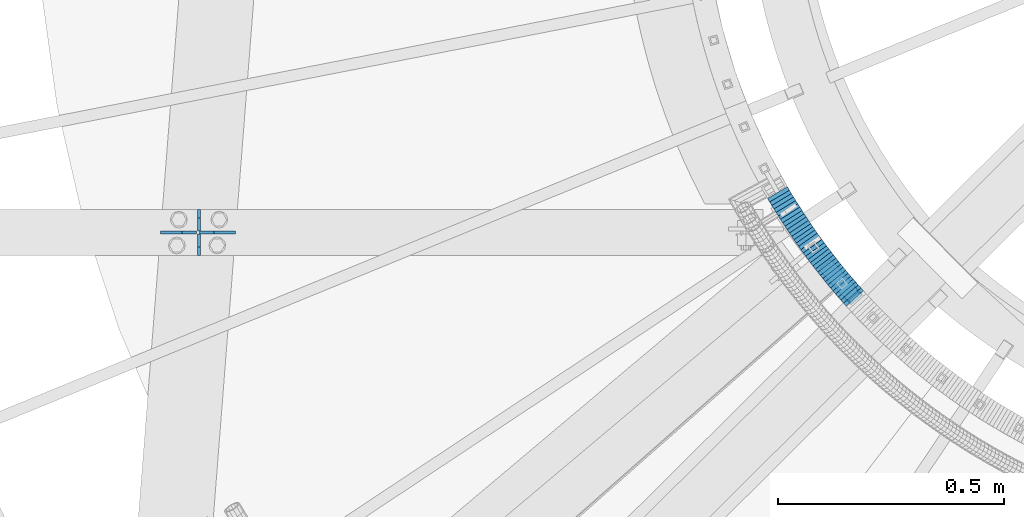
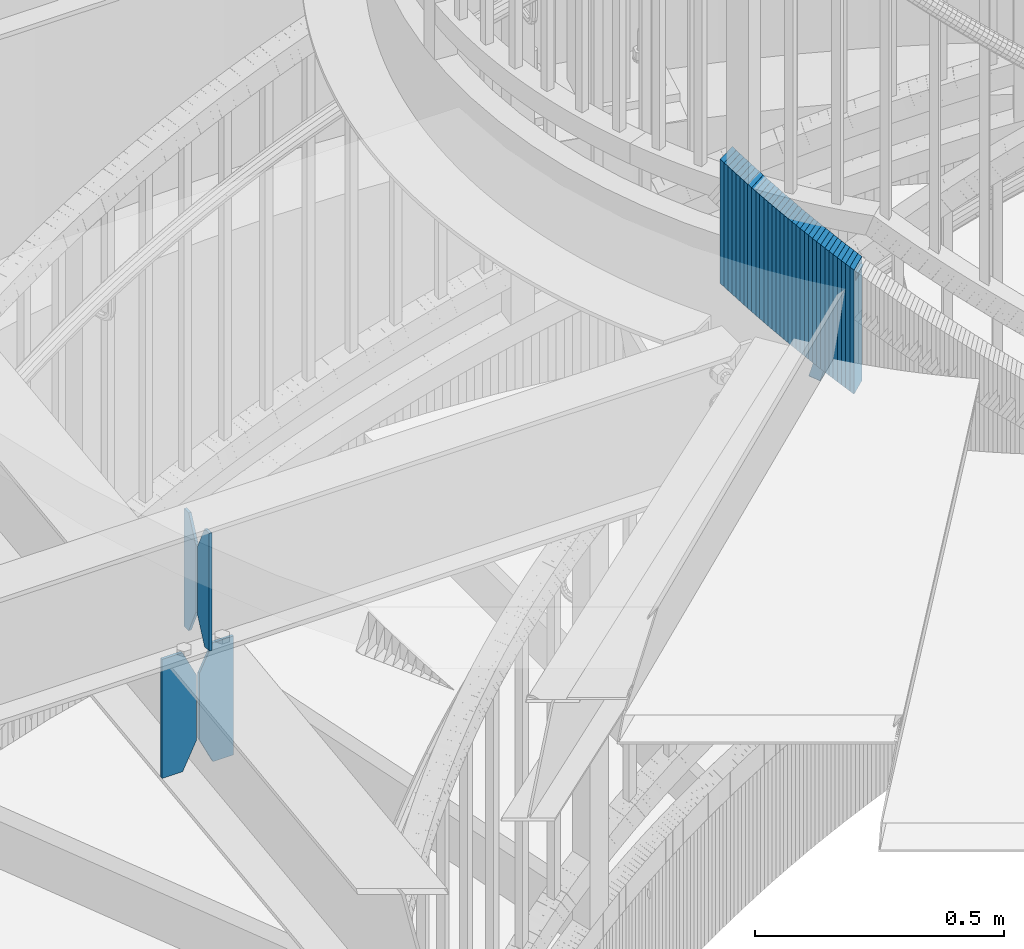
# One storey, part 885 of 975: 38 plates.
"""IFC2X3 building model written with IfcOpenShell, lengths in millimetres."""

from ifc_helpers import new_model, si_unit, frame, origin_with_axes, place, context, subcontext, project, spatial, faceted_brep, material, type_object, element, save


model = new_model("IFC2X3")

# Units and contexts
model_context = context("Model", 3, precision=1e-05, world=origin_with_axes())
body_context = subcontext(model_context, "Body", "Model", "MODEL_VIEW")
ifc_project = project(units=[si_unit("LENGTHUNIT", "METRE", prefix="MILLI"), si_unit("AREAUNIT", "SQUARE_METRE"), si_unit("VOLUMEUNIT", "CUBIC_METRE"), si_unit("MASSUNIT", "GRAM", prefix="KILO"), si_unit("TIMEUNIT", "SECOND"), si_unit("PLANEANGLEUNIT", "RADIAN"), si_unit("SOLIDANGLEUNIT", "STERADIAN"), si_unit("THERMODYNAMICTEMPERATUREUNIT", "DEGREE_CELSIUS"), si_unit("LUMINOUSINTENSITYUNIT", "LUMEN")], contexts=[model_context])

# Site, building, storey
site_placement = place(None, origin_with_axes())
site = spatial("IfcSite", under=ifc_project, at=site_placement, CompositionType="ELEMENT")
building_placement = place(site_placement, origin_with_axes())
building = spatial("IfcBuilding", under=site, at=building_placement, Name="Undefined", CompositionType="ELEMENT")
storey_placement = place(building_placement, origin_with_axes())
storey = spatial("IfcBuildingStorey", under=building, at=storey_placement, Name="Undefined", CompositionType="ELEMENT", Elevation=0.0)

# Plates
ifc_material = material(Name="STEEL/A36")
plate_type_1 = type_object("IfcPlateType", PredefinedType="NOTDEFINED")
plate_1_placement = place(storey_placement, frame((32249.7360351807, 2561.62278820643, 3636.9625), z_axis=(0.0, 0.0, 1.0), x_axis=(3.01200002456351e-06, 0.999999999995464, 0.0)))
element("IfcPlate", 1, at=plate_1_placement, inside=storey, type_object=plate_type_1, material=ifc_material, Name="PLATE", context=body_context, shape_type="Brep", body=[
    faceted_brep([(0.0, -3.17499999999927, 0.0), (0.0, -3.17499999999927, 288.924987792969), (0.0, 3.17499999999927, 288.924987792969), (0.0, 3.17499999999927, 0.0), (19.0499992370605, -3.17499999999927, 288.924987792969), (19.0499992370605, 3.17499999999927, 288.924987792969), (47.625, -3.17499999999927, 227.012489318848), (47.625, 3.17499999999927, 227.012489318848), (47.625, -3.17499999999927, 61.9124984741211), (47.625, 3.17499999999927, 61.9124984741211), (19.0499992370605, -3.17499999999927, 0.0), (19.0499992370605, 3.17499999999927, 0.0)], [[[0, 1, 2, 3]], [[1, 4, 5, 2]], [[4, 6, 7, 5]], [[6, 8, 9, 7]], [[8, 10, 11, 9]], [[10, 0, 3, 11]], [[5, 7, 9, 11, 3, 2]], [[10, 8, 6, 4, 1, 0]]]),
])
plate_2_placement = place(storey_placement, frame((32249.7361977533, 2615.59778820619, 3636.9625), z_axis=(0.0, 0.0, 1.0), x_axis=(3.01200002456351e-06, 0.999999999995464, 0.0)))
element("IfcPlate", 2, at=plate_2_placement, inside=storey, type_object=plate_type_1, material=ifc_material, Name="PLATE", context=body_context, shape_type="Brep", body=[
    faceted_brep([(0.0, -3.17499999999927, 61.9124984741211), (0.0, -3.17499999999927, 227.012489318848), (0.0, 3.17499999999927, 227.012489318848), (0.0, 3.17499999999927, 61.9124984741211), (28.5750007629395, -3.17499999999927, 288.924987792969), (28.5750007629395, 3.17499999999927, 288.924987792969), (47.625, -3.17499999999927, 288.924987792969), (47.625, 3.17499999999927, 288.924987792969), (47.625, -3.17499999999927, 0.0), (47.625, 3.17499999999927, 0.0), (28.5750007629395, -3.17499999999927, 0.0), (28.5750007629395, 3.17499999999927, 0.0)], [[[0, 1, 2, 3]], [[1, 4, 5, 2]], [[4, 6, 7, 5]], [[6, 8, 9, 7]], [[8, 10, 11, 9]], [[10, 0, 3, 11]], [[5, 7, 9, 11, 3, 2]], [[10, 8, 6, 4, 1, 0]]]),
])
plate_type_2 = type_object("IfcPlateType", PredefinedType="NOTDEFINED")
plate_3_placement = place(storey_placement, frame((32330.4196703415, 2612.42244990032, 3324.225), z_axis=(0.0, 0.0, 1.0), x_axis=(-0.999999999991335, 4.16299999770227e-06, 0.0)))
element("IfcPlate", 3, at=plate_3_placement, inside=storey, type_object=plate_type_2, material=ifc_material, Name="PLATE", context=body_context, shape_type="Brep", body=[
    faceted_brep([(0.0, -3.17499999999927, 0.0), (0.0, -3.17499999999973, 292.100006103516), (3.63797880709171e-12, 3.17500000000018, 292.100006103516), (0.0, 3.17499999999927, 0.0), (47.6250000000618, -3.17500000000382, 292.100006103516), (47.6250000000691, 3.17499999999654, 292.100006103516), (79.3750000001091, -3.175000000007, 227.012504577637), (79.3750000001164, 3.17499999999336, 227.012504577637), (79.3750000001091, -3.175000000007, 65.0875015258775), (79.3750000001164, 3.17499999999336, 65.0875015258775), (47.625, -3.17499999999927, 0.0), (47.625, 3.17499999999927, 0.0)], [[[0, 1, 2, 3]], [[1, 4, 5, 2]], [[4, 6, 7, 5]], [[6, 8, 9, 7]], [[8, 10, 11, 9]], [[10, 0, 3, 11]], [[5, 7, 9, 11, 3, 2]], [[10, 8, 6, 4, 1, 0]]]),
])
plate_4_placement = place(storey_placement, frame((32244.1798474455, 2612.4228088895, 3324.225), z_axis=(0.0, 0.0, 1.0), x_axis=(-0.999999999991335, 4.16299999770227e-06, 0.0)))
element("IfcPlate", 4, at=plate_4_placement, inside=storey, type_object=plate_type_2, material=ifc_material, Name="PLATE", context=body_context, shape_type="Brep", body=[
    faceted_brep([(-3.63797880709171e-12, -3.17499999999973, 65.0875015258789), (0.0, -3.17499999999927, 227.012489318848), (0.0, 3.17499999999927, 227.012489318848), (0.0, 3.17500000000018, 65.0875015258789), (31.75000000004, -3.17500000000246, 292.100006103516), (31.7500000000473, 3.17499999999791, 292.100006103516), (79.3750000001055, -3.175000000007, 292.100006103516), (79.3750000001128, 3.17499999999336, 292.100006103516), (79.3750000001055, -3.175000000007, 0.0), (79.3750000001128, 3.17499999999336, 0.0), (31.75000000004, -3.17500000000246, 0.0), (31.7500000000473, 3.17499999999791, 0.0)], [[[0, 1, 2, 3]], [[1, 4, 5, 2]], [[4, 6, 7, 5]], [[6, 8, 9, 7]], [[8, 10, 11, 9]], [[10, 0, 3, 11]], [[5, 7, 9, 11, 3, 2]], [[10, 8, 6, 4, 1, 0]]]),
])
plate_type_3 = type_object("IfcPlateType", PredefinedType="NOTDEFINED")
plate_5_placement = place(storey_placement, frame((33707.864757676, 2483.22474820831, 4132.26249923706), z_axis=(-0.182546044519055, 0.20525771042921, -0.961533262003872), x_axis=(-0.747238021792059, -0.664556497815114, 0.0)))
element("IfcPlate", 5, at=plate_5_placement, inside=storey, type_object=plate_type_3, material=ifc_material, Name="PLATE", context=body_context, shape_type="Brep", body=[
    faceted_brep([(34.9185449924807, -12.7000000002154, 293.586649641296), (34.9187276514203, -12.6999999999643, 6.35000394271628), (34.9187276514895, 12.7000000000917, 6.35000394272356), (34.9185449925571, 12.6999999998443, 293.586649641305), (34.4351788722088, -12.7000000002154, 296.016688160267), (34.4351788722779, 12.699999999837, 296.016688160273), (33.0586716532671, -12.7000000002226, 298.076775023996), (33.0586716533435, 12.6999999998407, 298.076775024005), (30.9985839141882, -12.7000000002263, 299.453280932887), (30.998583914261, 12.6999999998334, 299.453280932894), (28.56854508783, -12.7000000002299, 299.936645507854), (28.5685450879064, 12.6999999998261, 299.93664550786), (6.34981226485252, -12.7000000002699, 299.936645507842), (6.34981226492528, 12.6999999997897, 299.936645507849), (3.91977156843859, -12.7000000002772, 299.45328015827), (3.91977156851499, 12.6999999997861, 299.453280158277), (1.85968283685725, -12.7000000002772, 298.076772161423), (1.85968283693364, 12.6999999997824, 298.07677216143), (0.483176156678383, -12.7000000002772, 296.01668255008), (0.483176156747504, 12.6999999997824, 296.016682550087), (-0.000187639787327498, -12.7000000002736, 293.586641544742), (-0.000187639718205901, 12.6999999997788, 293.586641544747), (-4.05850369133987e-06, -12.7000000000298, 6.34999584616526), (-4.05842729378492e-06, 12.7000000000335, 6.34999584617253), (0.483362067625421, -12.7000000000262, 3.91995733345902), (0.483362067694543, 12.7000000000298, 3.91995733346448), (34.4353638491048, -12.6999999999607, 3.91996294363889), (34.4353638491739, 12.7000000000917, 3.91996294364617), (34.2223702437659, 12.700000000088, 3.60119521211527), (0.69634935641443, 12.7000000000335, 3.60119960543489), (1.85986928793864, -6.02054371066697, 1.85987047665003), (1.85986928797502, 6.5590248106455, 1.85987047665185), (3.91995702453278, -1.56509787831965, 0.483364573019571), (3.91995702454369, 1.70463654776177, 0.48336457302139), (6.34999584618345, -0.000756837067456217, 3.63797880709171e-12), (30.9987684385123, -1.56832783888967, 0.483365347628933), (33.0588571675798, -6.02427150299627, 1.8598733392173), (28.5687277468096, -0.00340503002735204, 9.09494701772928e-12), (30.9987684385233, 1.70465179357416, 0.483365347630752), (33.0588571676126, 6.55904932393241, 1.85987333921912)], [[[0, 1, 2, 3]], [[4, 0, 3, 5]], [[6, 4, 5, 7]], [[8, 6, 7, 9]], [[10, 8, 9, 11]], [[12, 10, 11, 13]], [[14, 12, 13, 15]], [[16, 14, 15, 17]], [[18, 16, 17, 19]], [[20, 18, 19, 21]], [[22, 20, 21, 23]], [[24, 22, 23, 25]], [[1, 0, 4, 6, 8, 10, 12, 14, 16, 18, 20, 22, 24, 26]], [[1, 26, 27, 2]], [[25, 23, 21, 19, 17, 15, 13, 11, 9, 7, 5, 3, 2, 27, 28, 29]], [[30, 24, 25, 29, 31]], [[32, 30, 31, 33]], [[32, 33, 34]], [[35, 36, 26, 24, 30, 32, 34, 37]], [[35, 37, 38]], [[36, 35, 38, 39]], [[27, 26, 36, 39, 28]], [[38, 37, 34, 33, 31, 29, 28, 39]]]),
])
plate_type_4 = type_object("IfcPlateType", PredefinedType="NOTDEFINED")
plate_6_placement = place(storey_placement, frame((33531.7439250375, 2692.97674915964, 4016.92500005032), z_axis=(-0.50798502015356, 0.86136590326039, 0.0), x_axis=(0.0, 0.0, 1.0)))
element("IfcPlate", 6, at=plate_6_placement, inside=storey, type_object=plate_type_4, material=ifc_material, Name="WALL", context=body_context, shape_type="Brep", body=[
    faceted_brep([(0.0, -25.3999999999724, -1.81898940354586e-11), (5.80000019073486, -25.4000000000487, 9.05538558962689), (5.80000019073486, 25.4000000000888, 9.0553855895505), (0.0, 25.3999999999869, 1.45519152283669e-11), (310.600006103516, -25.4000000000487, 9.05538558962689), (310.600006103516, 25.4000000000888, 9.0553855895505), (304.799987792969, -25.3999999999724, -1.81898940354586e-11), (304.799987792969, 25.3999999999869, 1.45519152283669e-11)], [[[0, 1, 2, 3]], [[1, 4, 5, 2]], [[4, 6, 7, 5]], [[6, 0, 3, 7]], [[5, 7, 3, 2]], [[6, 4, 1, 0]]]),
])
plate_7_placement = place(storey_placement, frame((33536.3209022962, 2685.38311613614, 4011.12500005032), z_axis=(-0.516109704254785, 0.856522488422831, 0.0), x_axis=(0.0, 0.0, 1.0)))
element("IfcPlate", 7, at=plate_7_placement, inside=storey, type_object=plate_type_4, material=ifc_material, Name="WALL", context=body_context, shape_type="Brep", body=[
    faceted_brep([(0.0, -25.3999999999724, -1.81898940354586e-11), (5.80000019073486, -25.4000000000051, 9.10659122468314), (5.80000019073486, 25.3999999999687, 9.1065912246886), (0.0, 25.3999999999869, 1.45519152283669e-11), (310.600006103516, -25.4000000000051, 9.10659122468314), (310.600006103516, 25.3999999999687, 9.1065912246886), (304.799987792969, -25.3999999999724, -1.81898940354586e-11), (304.799987792969, 25.3999999999869, 1.45519152283669e-11)], [[[0, 1, 2, 3]], [[1, 4, 5, 2]], [[4, 6, 7, 5]], [[6, 0, 3, 7]], [[5, 7, 3, 2]], [[6, 4, 1, 0]]]),
])
for number, where, z_axis, x_axis, name in (
    (8, (33540.9455466537, 2677.80736901084, 4005.32500005032), (-0.521001549732899, 0.853555730562403, 0.0), (0.0, 0.0, 1.0), "WALL"),
    (9, (33545.6455466609, 2670.10736901043, 3999.52500005032), (-0.521001549732899, 0.853555730562403, 0.0), (0.0, 0.0, 1.0), "WALL"),
):
    element("IfcPlate", number, at=place(storey_placement, frame(where, z_axis=z_axis, x_axis=x_axis)), inside=storey, type_object=plate_type_4, material=ifc_material, Name=name, context=body_context, shape_type="Brep", body=[
        faceted_brep([(0.0, -25.3999999999724, -1.81898940354586e-11), (5.80000019073486, -25.4000000000997, 9.0210866928719), (5.80000019073486, 25.4000000000451, 9.02108669277732), (0.0, 25.3999999999869, 1.45519152283669e-11), (310.600006103516, -25.4000000000997, 9.0210866928719), (310.600006103516, 25.4000000000451, 9.02108669277732), (304.799987792969, -25.3999999999724, -1.81898940354586e-11), (304.799987792969, 25.3999999999869, 1.45519152283669e-11)], [[[0, 1, 2, 3]], [[1, 4, 5, 2]], [[4, 6, 7, 5]], [[6, 0, 3, 7]], [[5, 7, 3, 2]], [[6, 4, 1, 0]]]),
    ])
plate_8_placement = place(storey_placement, frame((33550.3200999166, 2662.61073098628, 3993.72500005032), z_axis=(-0.529007926750978, 0.848616882600524, 0.0), x_axis=(0.0, 0.0, 1.0)))
element("IfcPlate", 10, at=plate_8_placement, inside=storey, type_object=plate_type_4, material=ifc_material, Name="WALL", context=body_context, shape_type="Brep", body=[
    faceted_brep([(0.0, -25.3999999999724, -1.81898940354586e-11), (5.80000019073486, -25.3999999999542, 9.07358837124957), (5.80000019073486, 25.3999999999542, 9.0735883713096), (0.0, 25.3999999999869, 1.45519152283669e-11), (310.600006103516, -25.3999999999542, 9.07358837124957), (310.600006103516, 25.3999999999542, 9.0735883713096), (304.799987792969, -25.3999999999724, -1.81898940354586e-11), (304.799987792969, 25.3999999999869, 1.45519152283669e-11)], [[[0, 1, 2, 3]], [[1, 4, 5, 2]], [[4, 6, 7, 5]], [[6, 0, 3, 7]], [[5, 7, 3, 2]], [[6, 4, 1, 0]]]),
])
for number, where, z_axis, x_axis, name in (
    (11, (33555.040649244, 2655.13735162165, 3987.92500005032), (-0.533992991124615, 0.845488903197308, 0.0), (0.0, 0.0, 1.0), "WALL"),
    (12, (33559.8406492484, 2647.53735162178, 3982.12500005032), (-0.533992991124615, 0.845488903197308, 0.0), (0.0, 0.0, 1.0), "WALL"),
):
    element("IfcPlate", number, at=place(storey_placement, frame(where, z_axis=z_axis, x_axis=x_axis)), inside=storey, type_object=plate_type_4, material=ifc_material, Name=name, context=body_context, shape_type="Brep", body=[
        faceted_brep([(0.0, -25.3999999999724, -1.81898940354586e-11), (5.80000019073486, -25.4000000000815, 8.99388694768095), (5.80000019073486, 25.4000000000342, 8.99388694761365), (0.0, 25.3999999999869, 1.45519152283669e-11), (310.600006103516, -25.4000000000815, 8.99388694768095), (310.600006103516, 25.4000000000342, 8.99388694761365), (304.799987792969, -25.3999999999724, -1.81898940354586e-11), (304.799987792969, 25.3999999999869, 1.45519152283669e-11)], [[[0, 1, 2, 3]], [[1, 4, 5, 2]], [[4, 6, 7, 5]], [[6, 0, 3, 7]], [[5, 7, 3, 2]], [[6, 4, 1, 0]]]),
    ])
plate_9_placement = place(storey_placement, frame((33564.6128927186, 2640.13755357502, 3976.32500005032), z_axis=(-0.54187495777844, 0.840459118656353, 0.0), x_axis=(0.0, 0.0, 1.0)))
element("IfcPlate", 13, at=plate_9_placement, inside=storey, type_object=plate_type_4, material=ifc_material, Name="WALL", context=body_context, shape_type="Brep", body=[
    faceted_brep([(0.0, -25.3999999999724, -1.81898940354586e-11), (5.80000019073486, -25.3999999999942, 9.04267692565918), (5.80000019073486, 25.3999999999614, 9.04267692568101), (0.0, 25.3999999999869, 1.45519152283669e-11), (310.600006103516, -25.3999999999942, 9.04267692565918), (310.600006103516, 25.3999999999614, 9.04267692568101), (304.799987792969, -25.3999999999724, -1.81898940354586e-11), (304.799987792969, 25.3999999999869, 1.45519152283669e-11)], [[[0, 1, 2, 3]], [[1, 4, 5, 2]], [[4, 6, 7, 5]], [[6, 0, 3, 7]], [[5, 7, 3, 2]], [[6, 4, 1, 0]]]),
])
plate_10_placement = place(storey_placement, frame((33569.3993085886, 2632.96331463178, 3970.52500005032), z_axis=(-0.554700196225226, 0.832050294337846, 0.0), x_axis=(0.0, 0.0, 1.0)))
element("IfcPlate", 14, at=plate_10_placement, inside=storey, type_object=plate_type_4, material=ifc_material, Name="WALL", context=body_context, shape_type="Brep", body=[
    faceted_brep([(0.0, -25.3999999999724, -1.81898940354586e-11), (5.80000019073486, -25.400000000016, 9.01387786866326), (5.80000019073486, 25.4000000000306, 9.01387786864143), (0.0, 25.3999999999869, 1.45519152283669e-11), (310.600006103515, -25.400000000016, 9.01387786866326), (310.600006103515, 25.4000000000306, 9.01387786864143), (304.799987792969, -25.3999999999724, -1.81898940354586e-11), (304.799987792969, 25.3999999999869, 1.45519152283669e-11)], [[[0, 1, 2, 3]], [[1, 4, 5, 2]], [[4, 6, 7, 5]], [[6, 0, 3, 7]], [[5, 7, 3, 2]], [[6, 4, 1, 0]]]),
])
plate_11_placement = place(storey_placement, frame((33574.3113909202, 2625.69430788527, 3964.82500005032), z_axis=(-0.559857410943981, 0.8285889689171, 0.0), x_axis=(0.0, 0.0, 1.0)))
element("IfcPlate", 15, at=plate_11_placement, inside=storey, type_object=plate_type_4, material=ifc_material, Name="WALL", context=body_context, shape_type="Brep", body=[
    faceted_brep([(0.0, -25.3999999999724, -1.81898940354586e-11), (5.69999980926514, -25.3999999999542, 8.93084526058738), (5.69999980926514, 25.3999999999178, 8.93084526067832), (0.0, 25.3999999999869, 1.45519152283669e-11), (310.5, -25.3999999999542, 8.93084526058738), (310.5, 25.3999999999178, 8.93084526067832), (304.799987792969, -25.3999999999724, -1.81898940354586e-11), (304.799987792969, 25.3999999999869, 1.45519152283669e-11)], [[[0, 1, 2, 3]], [[1, 4, 5, 2]], [[4, 6, 7, 5]], [[6, 0, 3, 7]], [[5, 7, 3, 2]], [[6, 4, 1, 0]]]),
])
plate_12_placement = place(storey_placement, frame((33579.3993085935, 2618.06331463161, 3959.02500005032), z_axis=(-0.554700196225226, 0.832050294337846, 0.0), x_axis=(0.0, 0.0, 1.0)))
element("IfcPlate", 16, at=plate_12_placement, inside=storey, type_object=plate_type_4, material=ifc_material, Name="WALL", context=body_context, shape_type="Brep", body=[
    faceted_brep([(0.0, -25.3999999999724, -1.81898940354586e-11), (5.80000019073486, -25.400000000016, 9.01387786866326), (5.80000019073486, 25.4000000000306, 9.01387786864143), (0.0, 25.3999999999869, 1.45519152283669e-11), (310.600006103515, -25.400000000016, 9.01387786866326), (310.600006103515, 25.4000000000306, 9.01387786864143), (304.799987792969, -25.3999999999724, -1.81898940354586e-11), (304.799987792969, 25.3999999999869, 1.45519152283669e-11)], [[[0, 1, 2, 3]], [[1, 4, 5, 2]], [[4, 6, 7, 5]], [[6, 0, 3, 7]], [[5, 7, 3, 2]], [[6, 4, 1, 0]]]),
])
plate_13_placement = place(storey_placement, frame((33584.3113909251, 2610.79430788501, 3953.32500005032), z_axis=(-0.559857410943981, 0.8285889689171, 0.0), x_axis=(0.0, 0.0, 1.0)))
element("IfcPlate", 17, at=plate_13_placement, inside=storey, type_object=plate_type_4, material=ifc_material, Name="WALL", context=body_context, shape_type="Brep", body=[
    faceted_brep([(0.0, -25.3999999999724, -1.81898940354586e-11), (5.69999980926514, -25.3999999999542, 8.93084526058738), (5.69999980926514, 25.3999999999178, 8.93084526067832), (0.0, 25.3999999999869, 1.45519152283669e-11), (310.5, -25.3999999999542, 8.93084526058738), (310.5, 25.3999999999178, 8.93084526067832), (304.799987792969, -25.3999999999724, -1.81898940354586e-11), (304.799987792969, 25.3999999999869, 1.45519152283669e-11)], [[[0, 1, 2, 3]], [[1, 4, 5, 2]], [[4, 6, 7, 5]], [[6, 0, 3, 7]], [[5, 7, 3, 2]], [[6, 4, 1, 0]]]),
])
plate_14_placement = place(storey_placement, frame((33589.1871132143, 2603.82072399449, 3947.52500005032), z_axis=(-0.572708438875059, 0.819759137821161, 0.0), x_axis=(0.0, 0.0, 1.0)))
element("IfcPlate", 18, at=plate_14_placement, inside=storey, type_object=plate_type_4, material=ifc_material, Name="WALL", context=body_context, shape_type="Brep", body=[
    faceted_brep([(0.0, -25.3999999999724, -1.81898940354586e-11), (5.80000019073486, -25.3999999999796, 8.91403388975959), (5.80000019073486, 25.3999999999432, 8.91403388980689), (0.0, 25.3999999999869, 1.45519152283669e-11), (310.600006103515, -25.3999999999796, 8.91403388975959), (310.600006103515, 25.3999999999432, 8.91403388980689), (304.799987792969, -25.3999999999724, -1.81898940354586e-11), (304.799987792969, 25.3999999999869, 1.45519152283669e-11)], [[[0, 1, 2, 3]], [[1, 4, 5, 2]], [[4, 6, 7, 5]], [[6, 0, 3, 7]], [[5, 7, 3, 2]], [[6, 4, 1, 0]]]),
])
for number, where, z_axis, x_axis, name in (
    (19, (33594.2531923139, 2596.71055955421, 3941.82500005032), (-0.580182279825393, 0.81448666175488, 0.0), (0.0, 0.0, 1.0), "WALL"),
    (20, (33599.4531923055, 2589.41055955385, 3936.12500005032), (-0.580182279825393, 0.81448666175488, 0.0), (0.0, 0.0, 1.0), "WALL"),
):
    element("IfcPlate", number, at=place(storey_placement, frame(where, z_axis=z_axis, x_axis=x_axis)), inside=storey, type_object=plate_type_4, material=ifc_material, Name=name, context=body_context, shape_type="Brep", body=[
        faceted_brep([(0.0, -25.3999999999724, -1.81898940354586e-11), (5.69999980926514, -25.3999999999105, 8.96270084374919), (5.69999980926514, 25.399999999936, 8.96270084385469), (0.0, 25.3999999999869, 1.45519152283669e-11), (310.5, -25.3999999999105, 8.96270084374919), (310.5, 25.399999999936, 8.96270084385469), (304.799987792969, -25.3999999999724, -1.81898940354586e-11), (304.799987792969, 25.3999999999869, 1.45519152283669e-11)], [[[0, 1, 2, 3]], [[1, 4, 5, 2]], [[4, 6, 7, 5]], [[6, 0, 3, 7]], [[5, 7, 3, 2]], [[6, 4, 1, 0]]]),
    ])
plate_15_placement = place(storey_placement, frame((33604.653192297, 2582.1105595536, 3930.32500005032), z_axis=(-0.580182279825393, 0.81448666175488, 0.0), x_axis=(0.0, 0.0, 1.0)))
element("IfcPlate", 21, at=plate_15_placement, inside=storey, type_object=plate_type_4, material=ifc_material, Name="WALL", context=body_context, shape_type="Brep", body=[
    faceted_brep([(0.0, -25.3999999999724, -1.81898940354586e-11), (5.80000019073486, -25.3999999999105, 8.96270084375283), (5.80000019073486, 25.399999999936, 8.96270084385833), (0.0, 25.3999999999869, 1.45519152283669e-11), (310.600006103516, -25.3999999999105, 8.96270084375283), (310.600006103516, 25.399999999936, 8.96270084385833), (304.799987792969, -25.3999999999724, -1.81898940354586e-11), (304.799987792969, 25.3999999999869, 1.45519152283669e-11)], [[[0, 1, 2, 3]], [[1, 4, 5, 2]], [[4, 6, 7, 5]], [[6, 0, 3, 7]], [[5, 7, 3, 2]], [[6, 4, 1, 0]]]),
])
plate_16_placement = place(storey_placement, frame((33609.7564834758, 2575.04538972086, 3924.62500005032), z_axis=(-0.58549055413645, 0.810679228188926, 0.0), x_axis=(0.0, 0.0, 1.0)))
element("IfcPlate", 22, at=plate_16_placement, inside=storey, type_object=plate_type_4, material=ifc_material, Name="WALL", context=body_context, shape_type="Brep", body=[
    faceted_brep([(0.0, -25.3999999999724, -1.81898940354586e-11), (5.69999980926514, -25.4000000000306, 8.88144111634756), (5.69999980926514, 25.4000000000378, 8.88144111629663), (0.0, 25.3999999999869, 1.45519152283669e-11), (310.5, -25.4000000000306, 8.88144111634756), (310.5, 25.4000000000378, 8.88144111629663), (304.799987792969, -25.3999999999724, -1.81898940354586e-11), (304.799987792969, 25.3999999999869, 1.45519152283669e-11)], [[[0, 1, 2, 3]], [[1, 4, 5, 2]], [[4, 6, 7, 5]], [[6, 0, 3, 7]], [[5, 7, 3, 2]], [[6, 4, 1, 0]]]),
])
plate_17_placement = place(storey_placement, frame((33614.9207879291, 2568.03149231997, 3918.92500005032), z_axis=(-0.592817428097409, 0.805336884132332, 0.0), x_axis=(0.0, 0.0, 1.0)))
element("IfcPlate", 23, at=plate_17_placement, inside=storey, type_object=plate_type_4, material=ifc_material, Name="WALL", context=body_context, shape_type="Brep", body=[
    faceted_brep([(0.0, -25.3999999999724, -1.81898940354586e-11), (5.69999980926514, -25.4000000000851, 8.94035816198448), (5.69999980926514, 25.4000000000524, 8.94035816188989), (0.0, 25.3999999999869, 1.45519152283669e-11), (310.5, -25.4000000000851, 8.94035816198448), (310.5, 25.4000000000524, 8.94035816188989), (304.799987792969, -25.3999999999724, -1.81898940354586e-11), (304.799987792969, 25.3999999999869, 1.45519152283669e-11)], [[[0, 1, 2, 3]], [[1, 4, 5, 2]], [[4, 6, 7, 5]], [[6, 0, 3, 7]], [[5, 7, 3, 2]], [[6, 4, 1, 0]]]),
])
for number, where, z_axis, x_axis, name in (
    (24, (33620.0822624972, 2561.25026341463, 3913.22500005032), (-0.605367471213059, 0.795946119280134, 0.0), (0.0, 0.0, 1.0), "WALL"),
    (25, (33625.4822624924, 2554.15026341411, 3907.52500005032), (-0.605367471213059, 0.795946119280134, 0.0), (0.0, 0.0, 1.0), "WALL"),
):
    element("IfcPlate", number, at=place(storey_placement, frame(where, z_axis=z_axis, x_axis=x_axis)), inside=storey, type_object=plate_type_4, material=ifc_material, Name=name, context=body_context, shape_type="Brep", body=[
        faceted_brep([(0.0, -25.3999999999724, -1.81898940354586e-11), (5.69999980926514, -25.4000000000269, 8.9196414947728), (5.69999980926514, 25.3999999999796, 8.91964149476189), (0.0, 25.3999999999869, 1.45519152283669e-11), (310.5, -25.4000000000269, 8.9196414947728), (310.5, 25.3999999999796, 8.91964149476189), (304.799987792969, -25.3999999999724, -1.81898940354586e-11), (304.799987792969, 25.3999999999869, 1.45519152283669e-11)], [[[0, 1, 2, 3]], [[1, 4, 5, 2]], [[4, 6, 7, 5]], [[6, 0, 3, 7]], [[5, 7, 3, 2]], [[6, 4, 1, 0]]]),
    ])
plate_18_placement = place(storey_placement, frame((33630.7765003623, 2547.28833737437, 3901.82500005032), z_axis=(-0.610803453897759, 0.791782255867463, 0.0), x_axis=(0.0, 0.0, 1.0)))
element("IfcPlate", 26, at=plate_18_placement, inside=storey, type_object=plate_type_4, material=ifc_material, Name="WALL", context=body_context, shape_type="Brep", body=[
    faceted_brep([(0.0, -25.3999999999724, -1.81898940354586e-11), (5.69999980926514, -25.3999999999869, 8.84081459044683), (5.69999980926514, 25.3999999999796, 8.84081459047957), (0.0, 25.3999999999869, 1.45519152283669e-11), (310.5, -25.3999999999869, 8.84081459044683), (310.5, 25.3999999999796, 8.84081459047957), (304.799987792969, -25.3999999999724, -1.81898940354586e-11), (304.799987792969, 25.3999999999869, 1.45519152283669e-11)], [[[0, 1, 2, 3]], [[1, 4, 5, 2]], [[4, 6, 7, 5]], [[6, 0, 3, 7]], [[5, 7, 3, 2]], [[6, 4, 1, 0]]]),
])
for number, where, z_axis, x_axis, name in (
    (27, (33636.1377168753, 2540.4665970637, 3896.12500005032), (-0.61782155188774, 0.786318338857122, 0.0), (0.0, 0.0, 1.0), "WALL"),
    (28, (33641.6377168802, 2533.46659706408, 3890.42500005032), (-0.61782155188774, 0.786318338857122, 0.0), (0.0, 0.0, 1.0), "WALL"),
):
    element("IfcPlate", number, at=place(storey_placement, frame(where, z_axis=z_axis, x_axis=x_axis)), inside=storey, type_object=plate_type_4, material=ifc_material, Name=name, context=body_context, shape_type="Brep", body=[
        faceted_brep([(0.0, -25.3999999999724, -1.81898940354586e-11), (5.69999980926514, -25.3999999999469, 8.90224647518698), (5.69999980926514, 25.399999999936, 8.90224647526338), (0.0, 25.3999999999869, 1.45519152283669e-11), (310.5, -25.3999999999469, 8.90224647518698), (310.5, 25.399999999936, 8.90224647526338), (304.799987792969, -25.3999999999724, -1.81898940354586e-11), (304.799987792969, 25.3999999999869, 1.45519152283669e-11)], [[[0, 1, 2, 3]], [[1, 4, 5, 2]], [[4, 6, 7, 5]], [[6, 0, 3, 7]], [[5, 7, 3, 2]], [[6, 4, 1, 0]]]),
    ])
plate_19_placement = place(storey_placement, frame((33647.0273513532, 2526.7060545132, 3884.72500005032), z_axis=(-0.623312002638487, 0.781973239546469, 0.0), x_axis=(0.0, 0.0, 1.0)))
element("IfcPlate", 29, at=plate_19_placement, inside=storey, type_object=plate_type_4, material=ifc_material, Name="WALL", context=body_context, shape_type="Brep", body=[
    faceted_brep([(0.0, -25.3999999999724, -1.81898940354586e-11), (5.69999980926514, -25.399999999936, 8.82383155817661), (5.69999980926514, 25.3999999999542, 8.82383155827119), (0.0, 25.3999999999869, 1.45519152283669e-11), (310.5, -25.399999999936, 8.82383155817661), (310.5, 25.3999999999542, 8.82383155827119), (304.799987792969, -25.3999999999724, -1.81898940354586e-11), (304.799987792969, 25.3999999999869, 1.45519152283669e-11)], [[[0, 1, 2, 3]], [[1, 4, 5, 2]], [[4, 6, 7, 5]], [[6, 0, 3, 7]], [[5, 7, 3, 2]], [[6, 4, 1, 0]]]),
])
for number, where, z_axis, x_axis, name in (
    (30, (33652.4872666572, 2519.98021940788, 3879.02500005032), (-0.630168888270572, 0.776458094333385, 0.0), (0.0, 0.0, 1.0), "WALL"),
    (31, (33658.0872666497, 2513.08021940766, 3873.32500005032), (-0.630168888270572, 0.776458094333385, 0.0), (0.0, 0.0, 1.0), "WALL"),
):
    element("IfcPlate", number, at=place(storey_placement, frame(where, z_axis=z_axis, x_axis=x_axis)), inside=storey, type_object=plate_type_4, material=ifc_material, Name=name, context=body_context, shape_type="Brep", body=[
        faceted_brep([(0.0, -25.3999999999724, -1.81898940354586e-11), (5.69999980926514, -25.4000000000196, 8.88650703432359), (5.69999980926514, 25.3999999999614, 8.88650703433086), (0.0, 25.3999999999869, 1.45519152283669e-11), (310.5, -25.4000000000196, 8.88650703432359), (310.5, 25.3999999999614, 8.88650703433086), (304.799987792969, -25.3999999999724, -1.81898940354586e-11), (304.799987792969, 25.3999999999869, 1.45519152283669e-11)], [[[0, 1, 2, 3]], [[1, 4, 5, 2]], [[4, 6, 7, 5]], [[6, 0, 3, 7]], [[5, 7, 3, 2]], [[6, 4, 1, 0]]]),
    ])
for number, where, z_axis, x_axis, name in (
    (32, (33663.5310421084, 2506.59085949794, 3867.62500005032), (-0.642398813105216, 0.766370514125517, 0.0), (0.0, 0.0, 1.0), "WALL"),
    (33, (33669.2310421045, 2499.79085949797, 3861.92500005032), (-0.642398813105216, 0.766370514125517, 0.0), (0.0, 0.0, 1.0), "WALL"),
):
    element("IfcPlate", number, at=place(storey_placement, frame(where, z_axis=z_axis, x_axis=x_axis)), inside=storey, type_object=plate_type_4, material=ifc_material, Name=name, context=body_context, shape_type="Brep", body=[
        faceted_brep([(0.0, -25.3999999999724, -1.81898940354586e-11), (5.69999980926514, -25.3999999999724, 8.87299251554577), (5.69999980926514, 25.3999999999614, 8.87299251558943), (0.0, 25.3999999999869, 1.45519152283669e-11), (310.5, -25.3999999999724, 8.87299251554577), (310.5, 25.3999999999614, 8.87299251558943), (304.799987792969, -25.3999999999724, -1.81898940354586e-11), (304.799987792969, 25.3999999999869, 1.45519152283669e-11)], [[[0, 1, 2, 3]], [[1, 4, 5, 2]], [[4, 6, 7, 5]], [[6, 0, 3, 7]], [[5, 7, 3, 2]], [[6, 4, 1, 0]]]),
    ])
plate_20_placement = place(storey_placement, frame((33674.8113635006, 2493.23257962872, 3856.22500005032), z_axis=(-0.647978346010379, 0.761658757647842, 7.64916876505595e-11), x_axis=(0.0, 0.0, 1.0)))
element("IfcPlate", 34, at=plate_20_placement, inside=storey, type_object=plate_type_4, material=ifc_material, Name="WALL", context=body_context, shape_type="Brep", body=[
    faceted_brep([(0.0, -25.3999999999724, -1.81898940354586e-11), (5.69999980926514, -25.3999999999869, 8.7965898513612), (5.69999980926514, 25.4000000000378, 8.79658985135757), (0.0, 25.3999999999869, 1.45519152283669e-11), (310.5, -25.3999999999869, 8.7965898513612), (310.5, 25.4000000000378, 8.79658985135757), (304.799987792969, -25.3999999999724, -1.81898940354586e-11), (304.799987792969, 25.3999999999869, 1.45519152283669e-11)], [[[0, 1, 2, 3]], [[1, 4, 5, 2]], [[4, 6, 7, 5]], [[6, 0, 3, 7]], [[5, 7, 3, 2]], [[6, 4, 1, 0]]]),
])
plate_21_placement = place(storey_placement, frame((33680.4691878565, 2486.69825046789, 3850.62500005032), z_axis=(-0.65450081979011, 0.756061291757536, 0.0), x_axis=(0.0, 0.0, 1.0)))
element("IfcPlate", 35, at=plate_21_placement, inside=storey, type_object=plate_type_4, material=ifc_material, Name="WALL", context=body_context, shape_type="Brep", body=[
    faceted_brep([(0.0, -25.3999999999724, -1.81898940354586e-11), (5.59999990463257, -25.4000000000342, 8.86171531681612), (5.59999990463257, 25.4000000000051, 8.86171531677246), (0.0, 25.3999999999869, 1.45519152283669e-11), (310.399993896484, -25.4000000000342, 8.86171531681612), (310.399993896484, 25.4000000000051, 8.86171531677246), (304.799987792969, -25.3999999999724, -1.81898940354586e-11), (304.799987792969, 25.3999999999869, 1.45519152283669e-11)], [[[0, 1, 2, 3]], [[1, 4, 5, 2]], [[4, 6, 7, 5]], [[6, 0, 3, 7]], [[5, 7, 3, 2]], [[6, 4, 1, 0]]]),
])
plate_22_placement = place(storey_placement, frame((33686.26918785, 2479.99825046739, 3844.92500005032), z_axis=(-0.65450081979011, 0.756061291757536, 0.0), x_axis=(0.0, 0.0, 1.0)))
element("IfcPlate", 36, at=plate_22_placement, inside=storey, type_object=plate_type_4, material=ifc_material, Name="WALL", context=body_context, shape_type="Brep", body=[
    faceted_brep([(0.0, -25.3999999999724, -1.81898940354586e-11), (5.69999980926514, -25.4000000000378, 8.86171531681612), (5.69999980926514, 25.3999999999978, 8.86171531676882), (0.0, 25.3999999999869, 1.45519152283669e-11), (310.5, -25.4000000000378, 8.86171531681612), (310.5, 25.3999999999978, 8.86171531676882), (304.799987792969, -25.3999999999724, -1.81898940354586e-11), (304.799987792969, 25.3999999999869, 1.45519152283669e-11)], [[[0, 1, 2, 3]], [[1, 4, 5, 2]], [[4, 6, 7, 5]], [[6, 0, 3, 7]], [[5, 7, 3, 2]], [[6, 4, 1, 0]]]),
])
plate_23_placement = place(storey_placement, frame((33692.0277091676, 2473.46029099437, 3839.22500005032), z_axis=(-0.660880368115947, 0.750491265131667, 0.0), x_axis=(0.0, 0.0, 1.0)))
element("IfcPlate", 37, at=plate_23_placement, inside=storey, type_object=plate_type_4, material=ifc_material, Name="WALL", context=body_context, shape_type="Brep", body=[
    faceted_brep([(0.0, -25.3999999999724, -1.81898940354586e-11), (5.69999980926514, -25.3999999999542, 8.93084526058738), (5.69999980926514, 25.3999999999178, 8.93084526067832), (0.0, 25.3999999999869, 1.45519152283669e-11), (310.5, -25.3999999999542, 8.93084526058738), (310.5, 25.3999999999178, 8.93084526067832), (304.799987792969, -25.3999999999724, -1.81898940354586e-11), (304.799987792969, 25.3999999999869, 1.45519152283669e-11)], [[[0, 1, 2, 3]], [[1, 4, 5, 2]], [[4, 6, 7, 5]], [[6, 0, 3, 7]], [[5, 7, 3, 2]], [[6, 4, 1, 0]]]),
])
plate_24_placement = place(storey_placement, frame((33697.8869723915, 2466.91877264044, 3833.42500005032), z_axis=(-0.667119802986571, 0.744950446985005, 0.0), x_axis=(0.0, 0.0, 1.0)))
element("IfcPlate", 38, at=plate_24_placement, inside=storey, type_object=plate_type_4, material=ifc_material, Name="WALL", context=body_context, shape_type="Brep", body=[
    faceted_brep([(0.0, -25.3999999999724, -1.81898940354586e-11), (5.80000019073486, -25.4000000000815, 8.99388694768095), (5.80000019073486, 25.4000000000342, 8.99388694761365), (0.0, 25.3999999999869, 1.45519152283669e-11), (310.600006103516, -25.4000000000815, 8.99388694768095), (310.600006103516, 25.4000000000342, 8.99388694761365), (304.799987792969, -25.3999999999724, -1.81898940354586e-11), (304.799987792969, 25.3999999999869, 1.45519152283669e-11)], [[[0, 1, 2, 3]], [[1, 4, 5, 2]], [[4, 6, 7, 5]], [[6, 0, 3, 7]], [[5, 7, 3, 2]], [[6, 4, 1, 0]]]),
])

save(model, "model.ifc")
